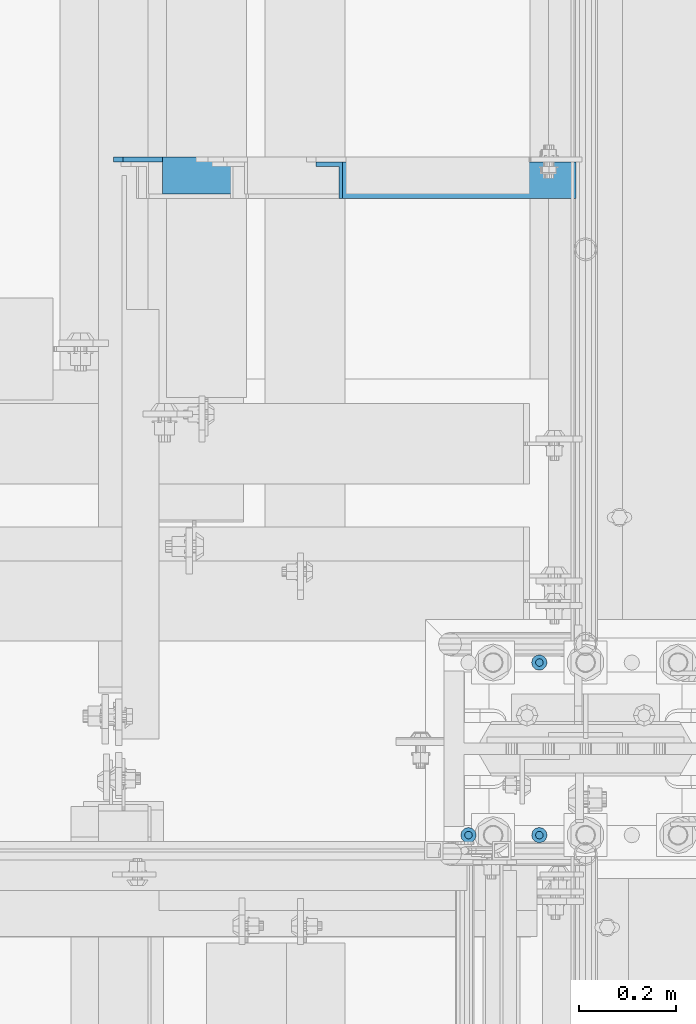
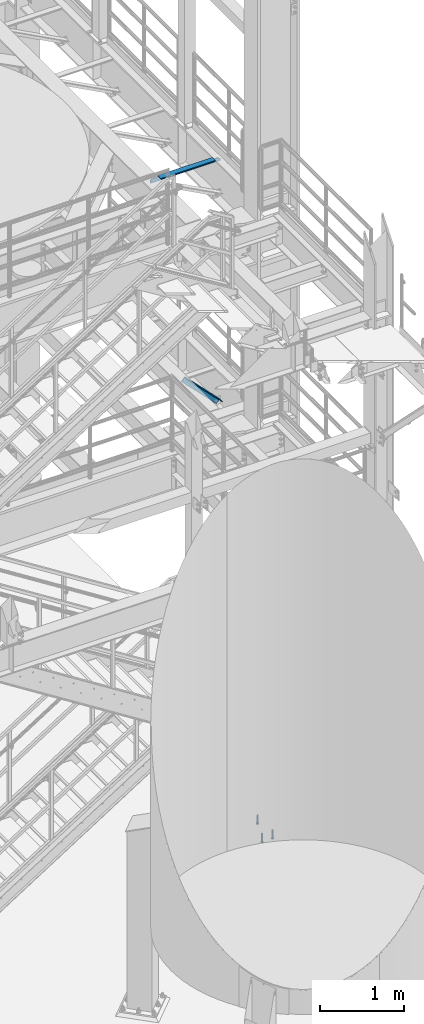
# One storey, part 1211 of 1876: 4 beams, 1 member, 3 elements without a shape of their own.
"""IFC2X3 building model written with IfcOpenShell, lengths in millimetres."""

from ifc_helpers import new_model, si_unit, frame, origin_with_axes, place, context, subcontext, project, spatial, faceted_brep, material, type_object, element, aggregate, save


model = new_model("IFC2X3")

# Units and contexts
model_context = context("Model", 3, precision=1e-05, world=origin_with_axes())
body_context = subcontext(model_context, "Body", "Model", "MODEL_VIEW")
ifc_project = project(units=[si_unit("LENGTHUNIT", "METRE", prefix="MILLI"), si_unit("AREAUNIT", "SQUARE_METRE"), si_unit("VOLUMEUNIT", "CUBIC_METRE"), si_unit("MASSUNIT", "GRAM", prefix="KILO"), si_unit("TIMEUNIT", "SECOND"), si_unit("PLANEANGLEUNIT", "RADIAN"), si_unit("SOLIDANGLEUNIT", "STERADIAN"), si_unit("THERMODYNAMICTEMPERATUREUNIT", "DEGREE_CELSIUS"), si_unit("LUMINOUSINTENSITYUNIT", "LUMEN")], contexts=[model_context])

# Site, building, storey
site_placement = place(None, origin_with_axes())
site = spatial("IfcSite", under=ifc_project, at=site_placement, CompositionType="ELEMENT")
building_placement = place(site_placement, origin_with_axes())
building = spatial("IfcBuilding", under=site, at=building_placement, Name="Undefined", CompositionType="ELEMENT")
storey_placement = place(building_placement, origin_with_axes())
storey = spatial("IfcBuildingStorey", under=building, at=storey_placement, Name="Undefined", CompositionType="ELEMENT", Elevation=0.0)

# Assembly, member
assembly_1_placement = place(storey_placement, origin_with_axes())
assembly_1 = element("IfcElementAssembly", 1, at=assembly_1_placement, inside=storey, AssemblyPlace="NOTDEFINED", PredefinedType="RIGID_FRAME")
ifc_material_1 = material(Name="STEEL/A36")
member_type = type_object("IfcMemberType", Name="L3X3X3/8", PredefinedType="NOTDEFINED")
member_placement = place(assembly_1_placement, frame((7040.82073558349, -3400.425, 5132.08684596299), z_axis=(0.0, -1.0, 0.0), x_axis=(0.701378051870177, 0.0, -0.712789469868064)))
member = element("IfcMember", 2, at=member_placement, type_object=member_type, material=ifc_material_1, ObjectType="L3X3X3/8", context=body_context, shape_type="Brep", body=[
    faceted_brep([(758.761261852226, 28.5750000000353, 38.0999999999999), (758.761261852226, 28.5750000000353, -28.5749999999998), (758.761261852226, -38.0999999999494, -28.5749999999998), (758.761261852226, -38.0999999999494, -38.0999999999999), (758.761261852226, 38.1000000000313, -38.0999999999999), (758.761261852226, 38.1000000000313, 38.0999999999999), (72.7035731357846, 28.5749999999971, 38.0999999999999), (72.7035731357846, 28.5749999999971, -28.5749999999998), (72.7035731357837, -38.0999999999876, -28.5749999999998), (72.7035731357837, -38.0999999999876, -38.0999999999999), (72.7035731357851, 38.0999999999949, -38.0999999999999), (72.7035731357851, 38.0999999999949, 38.0999999999999)], [[[0, 1, 2, 3, 4, 5]], [[1, 0, 6, 7]], [[2, 1, 7, 8]], [[3, 2, 8, 9]], [[4, 3, 9, 10]], [[5, 4, 10, 11]], [[0, 5, 11, 6]], [[10, 9, 8, 7, 6, 11]]]),
])
aggregate(assembly_1, [member])

# Assembly, beam
assembly_2_placement = place(storey_placement, origin_with_axes())
assembly_2 = element("IfcElementAssembly", 3, at=assembly_2_placement, inside=storey, Name="ANGLE", AssemblyPlace="NOTDEFINED", PredefinedType="RIGID_FRAME")
beam_type_1 = type_object("IfcBeamType", Name="L3X3X3/8", PredefinedType="NOTDEFINED")
beam_1_placement = place(assembly_2_placement, frame((6642.10000000027, -3390.9, 8115.3), z_axis=(0.0, -1.0, 0.0), x_axis=(1.0, 0.0, 0.0)))
beam_1 = element("IfcBeam", 4, at=beam_1_placement, type_object=beam_type_1, material=ifc_material_1, Name="ANGLE", ObjectType="L3X3X3/8", context=body_context, shape_type="Brep", body=[
    faceted_brep([(862.013000301767, 28.5749999999998, -28.5749999999998), (862.013001168541, 28.5749999999998, 38.0999999999999), (106.361999785874, 28.5749999999998, 38.0999999999999), (106.361998852422, 28.5749999999998, -28.5749999999998), (862.013001168541, 38.1000000000004, 38.0999999999999), (106.36199978587, 38.1000000000004, 38.0999999999999), (24.6062501036349, 20.6380008697515, -28.5749999999998), (24.6062499702866, 20.6380008697515, -38.0999999999999), (5.55625073322608, 1.58800163269098, -38.0999999999999), (5.55625086657437, 1.58800163269098, -28.5749999999998), (106.361998852423, 20.6380008697515, -28.5749999999998), (106.361998719075, 20.6380008697515, -38.0999999999999), (106.361998719068, 38.1000000000004, -38.0999999999999), (862.013000177942, 38.1000000000004, -38.0999999999999), (862.013000301742, 12.6999992370602, -28.5749999999998), (862.013000177913, 12.6999992370602, -38.0999999999999), (939.006248287582, 12.6999992370602, -28.5749999999998), (939.006248163753, 12.6999992370602, -38.0999999999999), (970.756248287582, -19.0500007629398, -28.5749999999998), (970.756248163753, -19.0500007629398, -38.0999999999999), (970.75624999973, -38.1000000000004, -28.5749999999998), (970.75624999973, -38.1000000000004, -38.0999999999999), (5.55625000000055, -38.1000000000004, -28.5749999999998), (5.55625000000055, -38.1000000000004, -38.1000000000004), (5.55625073322608, -4.76199874877875, -38.0999999999999), (5.55625086657437, -4.76199874877875, -28.5749999999998)], [[[0, 1, 2, 3]], [[1, 4, 5, 2]], [[6, 7, 8, 9]], [[10, 11, 7, 6]], [[2, 5, 12, 11, 10, 3]], [[4, 13, 12, 5]], [[1, 0, 14, 15, 13, 4]], [[16, 17, 15, 14]], [[17, 16, 18, 19]], [[19, 18, 20, 21]], [[21, 20, 22, 23]], [[8, 7, 11, 12, 13, 15, 17, 19, 21, 23, 24]], [[9, 8, 24, 25]], [[20, 18, 16, 14, 0, 3, 10, 6, 9, 25, 22]], [[24, 23, 22, 25]]]),
])
aggregate(assembly_2, [beam_1])

# Assembly, beams
assembly_3_placement = place(storey_placement, origin_with_axes())
assembly_3 = element("IfcElementAssembly", 5, at=assembly_3_placement, inside=storey, Name="TEMPLATE", AssemblyPlace="NOTDEFINED", PredefinedType="RIGID_FRAME")
ifc_material_2 = material(Name="STEEL/A108")
beam_type_2 = type_object("IfcBeamType", Name="5/8-DIA_HEADED ANCHOR STUD", PredefinedType="NOTDEFINED")
beam_2_placement = place(assembly_3_placement, frame((7378.7, -4749.8, -787.4), z_axis=(1.0, 0.0, 0.0), x_axis=(0.0, 0.0, -1.0)))
beam_2 = element("IfcBeam", 6, at=beam_2_placement, type_object=beam_type_2, material=ifc_material_2, Name="HEADED ANCHOR STUD", ObjectType="5/8-DIA_HEADED ANCHOR STUD", context=body_context, shape_type="Brep", body=[
    faceted_brep([(0.0, -7.94000005722046, 0.0), (0.0, -6.86999988555908, -3.97000002861023), (116.84, -6.86999988555908, -3.97000002861023), (116.84, -7.94000005722046, 0.0), (0.0, -3.97000002861023, -6.86999988555908), (116.84, -3.97000002861023, -6.86999988555908), (0.0, 0.0, -7.94000005722046), (116.84, 0.0, -7.94000005722046), (0.0, 3.97000002861023, -6.86999988555908), (116.84, 3.97000002861023, -6.86999988555908), (0.0, 6.86999988555908, -3.97000002861023), (116.84, 6.86999988555908, -3.97000002861023), (0.0, 7.94000005722046, 0.0), (116.84, 7.94000005722046, 0.0), (0.0, 6.86999988555908, 3.97000002861023), (116.84, 6.86999988555908, 3.97000002861023), (0.0, 3.97000002861023, 6.86999988555908), (116.84, 3.97000002861023, 6.86999988555908), (0.0, 0.0, 7.94000005722046), (116.84, 0.0, 7.94000005722046), (0.0, -3.97000002861023, 6.86999988555908), (116.84, -3.97000002861023, 6.86999988555908), (0.0, -6.86999988555908, 3.97000002861023), (116.84, -6.86999988555908, 3.97000002861023), (118.11, -13.75, -7.94000005722046), (118.11, -15.8800001144409, 0.0), (118.11, -7.94000005722046, -13.75), (118.11, 0.0, -15.8800001144409), (118.11, 7.94000005722046, -13.75), (118.11, 13.75, -7.94000005722046), (118.11, 15.8800001144409, 0.0), (118.11, 13.75, 7.94000005722046), (118.11, 7.94000005722046, 13.75), (118.11, 0.0, 15.8800001144409), (118.11, -7.94000005722046, 13.75), (118.11, -13.75, 7.94000005722046), (127.0, -13.75, -7.94000005722046), (127.0, -15.8800001144409, 0.0), (127.0, -7.94000005722046, -13.75), (127.0, 0.0, -15.8800001144409), (127.0, 7.94000005722046, -13.75), (127.0, 13.75, -7.94000005722046), (127.0, 15.8800001144409, 0.0), (127.0, 13.75, 7.94000005722046), (127.0, 7.94000005722046, 13.75), (127.0, 0.0, 15.8800001144409), (127.0, -7.94000005722046, 13.75), (127.0, -13.75, 7.94000005722046)], [[[0, 1, 2, 3]], [[1, 4, 5, 2]], [[4, 6, 7, 5]], [[6, 8, 9, 7]], [[8, 10, 11, 9]], [[10, 12, 13, 11]], [[12, 14, 15, 13]], [[14, 16, 17, 15]], [[16, 18, 19, 17]], [[18, 20, 21, 19]], [[20, 22, 23, 21]], [[22, 0, 3, 23]], [[22, 20, 18, 16, 14, 12, 10, 8, 6, 4, 1, 0]], [[3, 2, 24, 25]], [[2, 5, 26, 24]], [[5, 7, 27, 26]], [[7, 9, 28, 27]], [[9, 11, 29, 28]], [[11, 13, 30, 29]], [[13, 15, 31, 30]], [[15, 17, 32, 31]], [[17, 19, 33, 32]], [[19, 21, 34, 33]], [[21, 23, 35, 34]], [[23, 3, 25, 35]], [[25, 24, 36, 37]], [[24, 26, 38, 36]], [[26, 27, 39, 38]], [[27, 28, 40, 39]], [[28, 29, 41, 40]], [[29, 30, 42, 41]], [[30, 31, 43, 42]], [[31, 32, 44, 43]], [[32, 33, 45, 44]], [[33, 34, 46, 45]], [[34, 35, 47, 46]], [[35, 25, 37, 47]], [[38, 39, 40, 41, 42, 43, 44, 45, 46, 47, 37, 36]]]),
])
beam_3_placement = place(assembly_3_placement, frame((7524.75, -4394.2, -787.4), z_axis=(1.0, 0.0, 0.0), x_axis=(0.0, 0.0, -1.0)))
beam_3 = element("IfcBeam", 7, at=beam_3_placement, type_object=beam_type_2, material=ifc_material_2, Name="HEADED ANCHOR STUD", ObjectType="5/8-DIA_HEADED ANCHOR STUD", context=body_context, shape_type="Brep", body=[
    faceted_brep([(0.0, -7.94000005722046, 0.0), (0.0, -6.86999988555908, -3.97000002861023), (116.84, -6.86999988555908, -3.97000002861023), (116.84, -7.94000005722046, 0.0), (0.0, -3.97000002861023, -6.86999988555908), (116.84, -3.97000002861023, -6.86999988555908), (0.0, 0.0, -7.94000005722046), (116.84, 0.0, -7.94000005722046), (0.0, 3.97000002861023, -6.86999988555908), (116.84, 3.97000002861023, -6.86999988555908), (0.0, 6.86999988555908, -3.97000002861023), (116.84, 6.86999988555908, -3.97000002861023), (0.0, 7.94000005722046, 0.0), (116.84, 7.94000005722046, 0.0), (0.0, 6.86999988555908, 3.97000002861023), (116.84, 6.86999988555908, 3.97000002861023), (0.0, 3.97000002861023, 6.86999988555908), (116.84, 3.97000002861023, 6.86999988555908), (0.0, 0.0, 7.94000005722046), (116.84, 0.0, 7.94000005722046), (0.0, -3.97000002861023, 6.86999988555908), (116.84, -3.97000002861023, 6.86999988555908), (0.0, -6.86999988555908, 3.97000002861023), (116.84, -6.86999988555908, 3.97000002861023), (118.11, -13.75, -7.94000005722046), (118.11, -15.8800001144409, 0.0), (118.11, -7.94000005722046, -13.75), (118.11, 0.0, -15.8800001144409), (118.11, 7.94000005722046, -13.75), (118.11, 13.75, -7.94000005722046), (118.11, 15.8800001144409, 0.0), (118.11, 13.75, 7.94000005722046), (118.11, 7.94000005722046, 13.75), (118.11, 0.0, 15.8800001144409), (118.11, -7.94000005722046, 13.75), (118.11, -13.75, 7.94000005722046), (127.0, -13.75, -7.94000005722046), (127.0, -15.8800001144409, 0.0), (127.0, -7.94000005722046, -13.75), (127.0, 0.0, -15.8800001144409), (127.0, 7.94000005722046, -13.75), (127.0, 13.75, -7.94000005722046), (127.0, 15.8800001144409, 0.0), (127.0, 13.75, 7.94000005722046), (127.0, 7.94000005722046, 13.75), (127.0, 0.0, 15.8800001144409), (127.0, -7.94000005722046, 13.75), (127.0, -13.75, 7.94000005722046)], [[[0, 1, 2, 3]], [[1, 4, 5, 2]], [[4, 6, 7, 5]], [[6, 8, 9, 7]], [[8, 10, 11, 9]], [[10, 12, 13, 11]], [[12, 14, 15, 13]], [[14, 16, 17, 15]], [[16, 18, 19, 17]], [[18, 20, 21, 19]], [[20, 22, 23, 21]], [[22, 0, 3, 23]], [[22, 20, 18, 16, 14, 12, 10, 8, 6, 4, 1, 0]], [[3, 2, 24, 25]], [[2, 5, 26, 24]], [[5, 7, 27, 26]], [[7, 9, 28, 27]], [[9, 11, 29, 28]], [[11, 13, 30, 29]], [[13, 15, 31, 30]], [[15, 17, 32, 31]], [[17, 19, 33, 32]], [[19, 21, 34, 33]], [[21, 23, 35, 34]], [[23, 3, 25, 35]], [[25, 24, 36, 37]], [[24, 26, 38, 36]], [[26, 27, 39, 38]], [[27, 28, 40, 39]], [[28, 29, 41, 40]], [[29, 30, 42, 41]], [[30, 31, 43, 42]], [[31, 32, 44, 43]], [[32, 33, 45, 44]], [[33, 34, 46, 45]], [[34, 35, 47, 46]], [[35, 25, 37, 47]], [[38, 39, 40, 41, 42, 43, 44, 45, 46, 47, 37, 36]]]),
])
beam_4_placement = place(assembly_3_placement, frame((7524.75, -4749.8, -787.4), z_axis=(1.0, 0.0, 0.0), x_axis=(0.0, 0.0, -1.0)))
beam_4 = element("IfcBeam", 8, at=beam_4_placement, type_object=beam_type_2, material=ifc_material_2, Name="HEADED ANCHOR STUD", ObjectType="5/8-DIA_HEADED ANCHOR STUD", context=body_context, shape_type="Brep", body=[
    faceted_brep([(0.0, -7.94000005722046, 0.0), (0.0, -6.86999988555908, -3.97000002861023), (116.84, -6.86999988555908, -3.97000002861023), (116.84, -7.94000005722046, 0.0), (0.0, -3.97000002861023, -6.86999988555908), (116.84, -3.97000002861023, -6.86999988555908), (0.0, 0.0, -7.94000005722046), (116.84, 0.0, -7.94000005722046), (0.0, 3.97000002861023, -6.86999988555908), (116.84, 3.97000002861023, -6.86999988555908), (0.0, 6.86999988555908, -3.97000002861023), (116.84, 6.86999988555908, -3.97000002861023), (0.0, 7.94000005722046, 0.0), (116.84, 7.94000005722046, 0.0), (0.0, 6.86999988555908, 3.97000002861023), (116.84, 6.86999988555908, 3.97000002861023), (0.0, 3.97000002861023, 6.86999988555908), (116.84, 3.97000002861023, 6.86999988555908), (0.0, 0.0, 7.94000005722046), (116.84, 0.0, 7.94000005722046), (0.0, -3.97000002861023, 6.86999988555908), (116.84, -3.97000002861023, 6.86999988555908), (0.0, -6.86999988555908, 3.97000002861023), (116.84, -6.86999988555908, 3.97000002861023), (118.11, -13.75, -7.94000005722046), (118.11, -15.8800001144409, 0.0), (118.11, -7.94000005722046, -13.75), (118.11, 0.0, -15.8800001144409), (118.11, 7.94000005722046, -13.75), (118.11, 13.75, -7.94000005722046), (118.11, 15.8800001144409, 0.0), (118.11, 13.75, 7.94000005722046), (118.11, 7.94000005722046, 13.75), (118.11, 0.0, 15.8800001144409), (118.11, -7.94000005722046, 13.75), (118.11, -13.75, 7.94000005722046), (127.0, -13.75, -7.94000005722046), (127.0, -15.8800001144409, 0.0), (127.0, -7.94000005722046, -13.75), (127.0, 0.0, -15.8800001144409), (127.0, 7.94000005722046, -13.75), (127.0, 13.75, -7.94000005722046), (127.0, 15.8800001144409, 0.0), (127.0, 13.75, 7.94000005722046), (127.0, 7.94000005722046, 13.75), (127.0, 0.0, 15.8800001144409), (127.0, -7.94000005722046, 13.75), (127.0, -13.75, 7.94000005722046)], [[[0, 1, 2, 3]], [[1, 4, 5, 2]], [[4, 6, 7, 5]], [[6, 8, 9, 7]], [[8, 10, 11, 9]], [[10, 12, 13, 11]], [[12, 14, 15, 13]], [[14, 16, 17, 15]], [[16, 18, 19, 17]], [[18, 20, 21, 19]], [[20, 22, 23, 21]], [[22, 0, 3, 23]], [[22, 20, 18, 16, 14, 12, 10, 8, 6, 4, 1, 0]], [[3, 2, 24, 25]], [[2, 5, 26, 24]], [[5, 7, 27, 26]], [[7, 9, 28, 27]], [[9, 11, 29, 28]], [[11, 13, 30, 29]], [[13, 15, 31, 30]], [[15, 17, 32, 31]], [[17, 19, 33, 32]], [[19, 21, 34, 33]], [[21, 23, 35, 34]], [[23, 3, 25, 35]], [[25, 24, 36, 37]], [[24, 26, 38, 36]], [[26, 27, 39, 38]], [[27, 28, 40, 39]], [[28, 29, 41, 40]], [[29, 30, 42, 41]], [[30, 31, 43, 42]], [[31, 32, 44, 43]], [[32, 33, 45, 44]], [[33, 34, 46, 45]], [[34, 35, 47, 46]], [[35, 25, 37, 47]], [[38, 39, 40, 41, 42, 43, 44, 45, 46, 47, 37, 36]]]),
])
aggregate(assembly_3, [beam_2, beam_3, beam_4])

save(model, "model.ifc")
